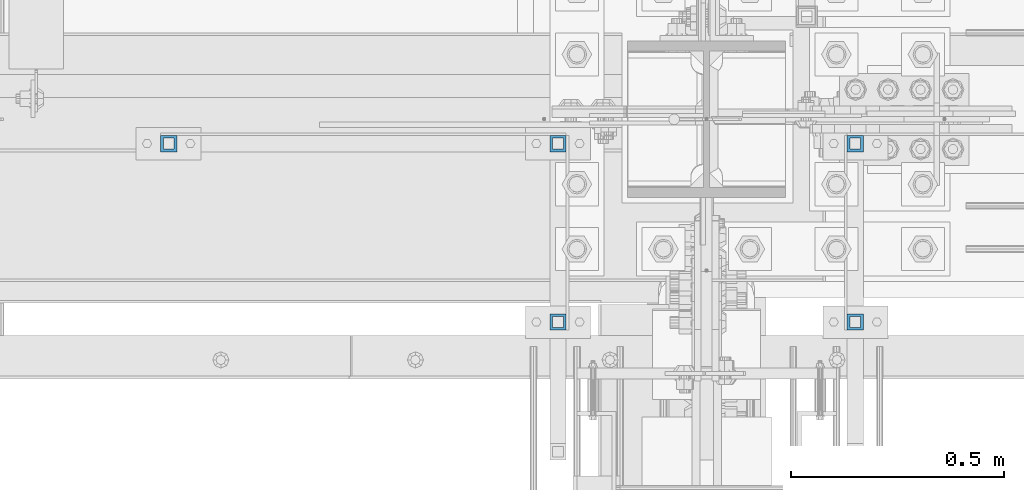
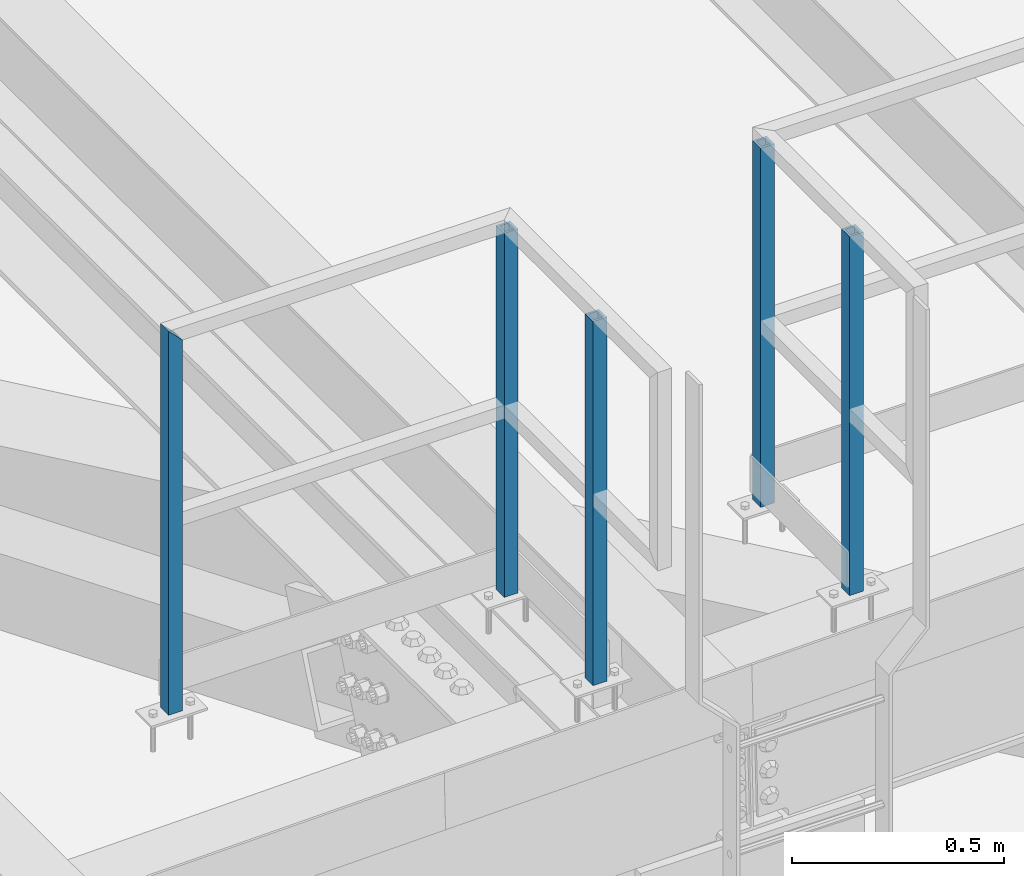
# One storey, part 1304 of 3843: 5 columns, 2 elements without a shape of their own.
"""IFC2X3 building model written with IfcOpenShell, lengths in millimetres."""

from ifc_helpers import new_model, si_unit, frame, origin_with_axes, place, context, subcontext, project, spatial, faceted_brep, material, type_object, element, aggregate, save


model = new_model("IFC2X3")

# Units and contexts
model_context = context("Model", 3, precision=1e-05, world=origin_with_axes())
body_context = subcontext(model_context, "Body", "Model", "MODEL_VIEW")
ifc_project = project(units=[si_unit("LENGTHUNIT", "METRE", prefix="MILLI"), si_unit("AREAUNIT", "SQUARE_METRE"), si_unit("VOLUMEUNIT", "CUBIC_METRE"), si_unit("MASSUNIT", "GRAM", prefix="KILO"), si_unit("TIMEUNIT", "SECOND"), si_unit("PLANEANGLEUNIT", "RADIAN"), si_unit("SOLIDANGLEUNIT", "STERADIAN"), si_unit("THERMODYNAMICTEMPERATUREUNIT", "DEGREE_CELSIUS"), si_unit("LUMINOUSINTENSITYUNIT", "LUMEN")], contexts=[model_context])

# Site, building, storey
site_placement = place(None, origin_with_axes())
site = spatial("IfcSite", under=ifc_project, at=site_placement, CompositionType="ELEMENT")
building_placement = place(site_placement, origin_with_axes())
building = spatial("IfcBuilding", under=site, at=building_placement, Name="Undefined", CompositionType="ELEMENT")
storey_placement = place(building_placement, origin_with_axes())
storey = spatial("IfcBuildingStorey", under=building, at=storey_placement, Name="Undefined", CompositionType="ELEMENT", Elevation=0.0)

# Assembly, columns
assembly_1_placement = place(storey_placement, origin_with_axes())
assembly_1 = element("IfcElementAssembly", 1, at=assembly_1_placement, inside=storey, Name="RAIL", AssemblyPlace="NOTDEFINED", PredefinedType="RIGID_FRAME")
ifc_material = material()
column_type = type_object("IfcColumnType", Name="HSS1-1/2X1-1/2X1/4", PredefinedType="NOTDEFINED")
column_1_placement = place(assembly_1_placement, frame((54667.150000765, 25558.75, 46304.2), z_axis=(1.0, 0.0, 0.0), x_axis=(0.0, 0.0, 1.0)))
column_1 = element("IfcColumn", 2, at=column_1_placement, type_object=column_type, material=ifc_material, Name="POST", ObjectType="HSS1-1/2X1-1/2X1/4", context=body_context, shape_type="Brep", body=[
    faceted_brep([(-20.3670143211639, 12.6999993300014, -12.6999993299978), (-20.3670143211639, -12.6999993300014, -12.6999993299978), (1079.49999933128, -12.6999993300014, -12.6999993299978), (1079.49999933128, 12.6999993300014, -12.6999993299978), (-20.3670143211639, -12.6999993300014, 12.6999993299978), (1054.10000067129, -12.6999993300014, 12.6999993299978), (-20.3670143211639, 12.6999993300014, 12.6999993299978), (1054.10000067129, 12.6999993300014, 12.6999993299978), (-20.3670143211639, 19.0499992350015, -19.0499992350015), (-20.3670143211639, 19.0499992350015, 19.0499992350015), (1047.75000076629, 19.0499992350015, 19.0499992349942), (1085.84999923629, 19.0499992350015, -19.0499992349942), (-20.3670143211639, -19.0499992350015, 19.0499992350015), (1047.75000076629, -19.0499992350015, 19.0499992349942), (-20.3670143211639, -19.0499992350015, -19.0499992350015), (1085.84999923629, -19.0499992350015, -19.0499992349942)], [[[0, 1, 2, 3]], [[1, 4, 5, 2]], [[4, 6, 7, 5]], [[6, 0, 3, 7]], [[8, 9, 10, 11]], [[9, 12, 13, 10]], [[12, 14, 15, 13]], [[14, 8, 11, 15]], [[13, 15, 11, 10], [5, 7, 3, 2]], [[14, 12, 9, 8], [6, 4, 1, 0]]]),
])
column_2_placement = place(assembly_1_placement, frame((55581.550000765, 25558.75, 46304.2), z_axis=(1.0, 0.0, 0.0), x_axis=(0.0, 0.0, 1.0)))
column_2 = element("IfcColumn", 3, at=column_2_placement, type_object=column_type, material=ifc_material, Name="POST", ObjectType="HSS1-1/2X1-1/2X1/4", context=body_context, shape_type="Brep", body=[
    faceted_brep([(-1.02120985595684, 12.6999993300014, -12.6999993299978), (-1.02120985595684, -12.6999993300014, -12.6999993299978), (1047.75000076497, -12.6999993300014, -12.6999993299978), (1047.75000076497, 12.6999993300014, -12.6999993299978), (-1.02120985595684, -12.6999993300014, 12.6999993299978), (1047.75000076497, -12.6999993300014, 12.6999993299978), (-1.02120985595684, 12.6999993300014, 12.6999993299978), (1047.75000076497, 12.6999993300014, 12.6999993299978), (-1.02120985595684, 19.0499992350015, -19.0499992350015), (-1.02120985595684, 19.0499992350015, 19.0499992350015), (1047.75000076629, 19.0499992350015, 19.0499992349942), (1047.750000765, 19.0499992350015, -19.0499992350015), (-1.02120985595684, -19.0499992350015, 19.0499992350015), (1047.75000076629, -19.0499992350015, 19.0499992349942), (-1.02120985595684, -19.0499992350015, -19.0499992350015), (1047.750000765, -19.0499992350015, -19.0499992350015)], [[[0, 1, 2, 3]], [[1, 4, 5, 2]], [[4, 6, 7, 5]], [[6, 0, 3, 7]], [[8, 9, 10, 11]], [[9, 12, 13, 10]], [[12, 14, 15, 13]], [[14, 8, 11, 15]], [[13, 15, 11, 10], [5, 7, 3, 2]], [[14, 12, 9, 8], [6, 4, 1, 0]]]),
])
column_3_placement = place(assembly_1_placement, frame((55581.5500007645, 25139.6500000003, 46304.2), z_axis=(1.0, 0.0, 0.0), x_axis=(0.0, 0.0, 1.0)))
column_3 = element("IfcColumn", 4, at=column_3_placement, type_object=column_type, material=ifc_material, Name="POST", ObjectType="HSS1-1/2X1-1/2X1/4", context=body_context, shape_type="Brep", body=[
    faceted_brep([(-1.02120985595684, 12.6999993300014, -12.6999993299978), (-1.02120985595684, -12.6999993300014, -12.6999993299978), (1047.75000076497, -12.6999993300014, -12.6999993299978), (1047.75000076497, 12.6999993300014, -12.6999993299978), (-1.02120985595684, -12.6999993300014, 12.6999993299978), (1047.75000076497, -12.6999993300014, 12.6999993299978), (-1.02120985595684, 12.6999993300014, 12.6999993299978), (1047.75000076497, 12.6999993300014, 12.6999993299978), (-1.02120985595684, 19.0499992350015, -19.0499992350015), (-1.02120985595684, 19.0499992350015, 19.0499992350015), (1047.75000076629, 19.0499992350015, 19.0499992349942), (1047.750000765, 19.0499992350015, -19.0499992350015), (-1.02120985595684, -19.0499992350015, 19.0499992350015), (1047.75000076629, -19.0499992350015, 19.0499992349942), (-1.02120985595684, -19.0499992350015, -19.0499992350015), (1047.750000765, -19.0499992350015, -19.0499992350015)], [[[0, 1, 2, 3]], [[1, 4, 5, 2]], [[4, 6, 7, 5]], [[6, 0, 3, 7]], [[8, 9, 10, 11]], [[9, 12, 13, 10]], [[12, 14, 15, 13]], [[14, 8, 11, 15]], [[13, 15, 11, 10], [5, 7, 3, 2]], [[14, 12, 9, 8], [6, 4, 1, 0]]]),
])
aggregate(assembly_1, [column_1, column_2, column_3])

assembly_2_placement = place(storey_placement, origin_with_axes())
assembly_2 = element("IfcElementAssembly", 5, at=assembly_2_placement, inside=storey, Name="RAIL", AssemblyPlace="NOTDEFINED", PredefinedType="RIGID_FRAME")
column_4_placement = place(assembly_2_placement, frame((56280.049999235, 25558.75, 46304.2), z_axis=(-1.0, 0.0, 0.0), x_axis=(0.0, 0.0, 1.0)))
column_4 = element("IfcColumn", 6, at=column_4_placement, type_object=column_type, material=ifc_material, Name="POST", ObjectType="HSS1-1/2X1-1/2X1/4", context=body_context, shape_type="Brep", body=[
    faceted_brep([(13.756836247936, 12.6999993300014, -12.6999993299978), (13.756836247936, -12.6999993300014, -12.6999993299978), (1047.75000076497, -12.6999993300014, -12.6999993299978), (1047.75000076497, 12.6999993300014, -12.6999993299978), (13.756836247936, -12.6999993300014, 12.6999993299978), (1047.75000076497, -12.6999993300014, 12.6999993299978), (13.756836247936, 12.6999993300014, 12.6999993299978), (1047.75000076497, 12.6999993300014, 12.6999993299978), (13.756836247936, 19.0499992350015, -19.0499992350015), (13.756836247936, 19.0499992350015, 19.0499992350015), (1047.75000076629, 19.0499992350015, 19.0499992349942), (1047.750000765, 19.0499992350015, -19.0499992350015), (13.756836247936, -19.0499992350015, 19.0499992350015), (1047.75000076629, -19.0499992350015, 19.0499992349942), (13.756836247936, -19.0499992350015, -19.0499992350015), (1047.750000765, -19.0499992350015, -19.0499992350015)], [[[0, 1, 2, 3]], [[1, 4, 5, 2]], [[4, 6, 7, 5]], [[6, 0, 3, 7]], [[8, 9, 10, 11]], [[9, 12, 13, 10]], [[12, 14, 15, 13]], [[14, 8, 11, 15]], [[13, 15, 11, 10], [5, 7, 3, 2]], [[14, 12, 9, 8], [6, 4, 1, 0]]]),
])
column_5_placement = place(assembly_2_placement, frame((56280.0499992355, 25139.6500000003, 46304.2), z_axis=(-1.0, 0.0, 0.0), x_axis=(0.0, 0.0, 1.0)))
column_5 = element("IfcColumn", 7, at=column_5_placement, type_object=column_type, material=ifc_material, Name="POST", ObjectType="HSS1-1/2X1-1/2X1/4", context=body_context, shape_type="Brep", body=[
    faceted_brep([(13.756836247936, 12.6999993300014, -12.6999993299978), (13.756836247936, -12.6999993300014, -12.6999993299978), (1047.75000076497, -12.6999993300014, -12.6999993299978), (1047.75000076497, 12.6999993300014, -12.6999993299978), (13.756836247936, -12.6999993300014, 12.6999993299978), (1047.75000076497, -12.6999993300014, 12.6999993299978), (13.756836247936, 12.6999993300014, 12.6999993299978), (1047.75000076497, 12.6999993300014, 12.6999993299978), (13.756836247936, 19.0499992350015, -19.0499992350015), (13.756836247936, 19.0499992350015, 19.0499992350015), (1047.75000076629, 19.0499992350015, 19.0499992349942), (1047.750000765, 19.0499992350015, -19.0499992350015), (13.756836247936, -19.0499992350015, 19.0499992350015), (1047.75000076629, -19.0499992350015, 19.0499992349942), (13.756836247936, -19.0499992350015, -19.0499992350015), (1047.750000765, -19.0499992350015, -19.0499992350015)], [[[0, 1, 2, 3]], [[1, 4, 5, 2]], [[4, 6, 7, 5]], [[6, 0, 3, 7]], [[8, 9, 10, 11]], [[9, 12, 13, 10]], [[12, 14, 15, 13]], [[14, 8, 11, 15]], [[13, 15, 11, 10], [5, 7, 3, 2]], [[14, 12, 9, 8], [6, 4, 1, 0]]]),
])
aggregate(assembly_2, [column_4, column_5])

save(model, "model.ifc")
